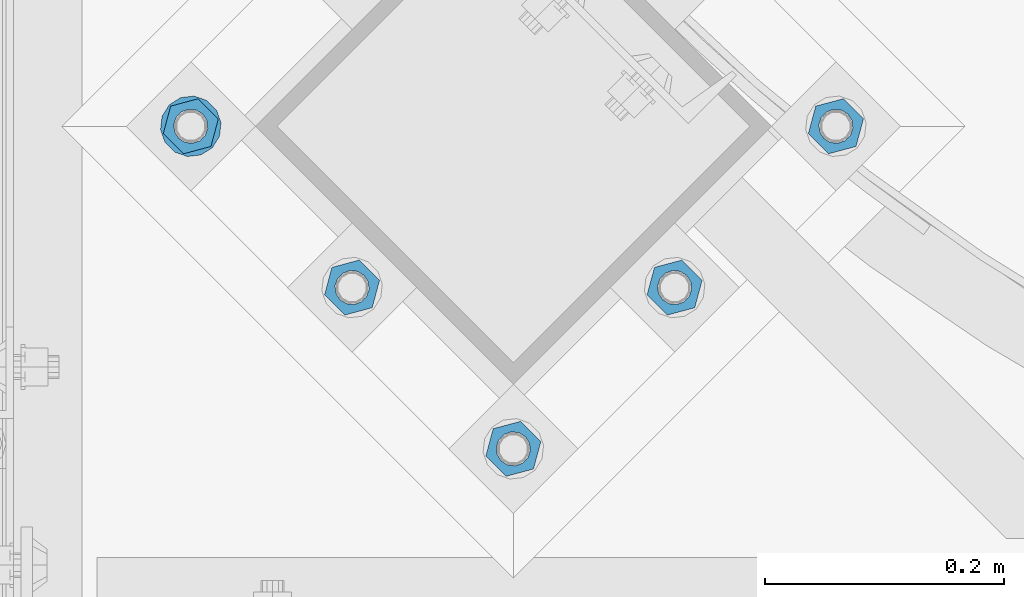
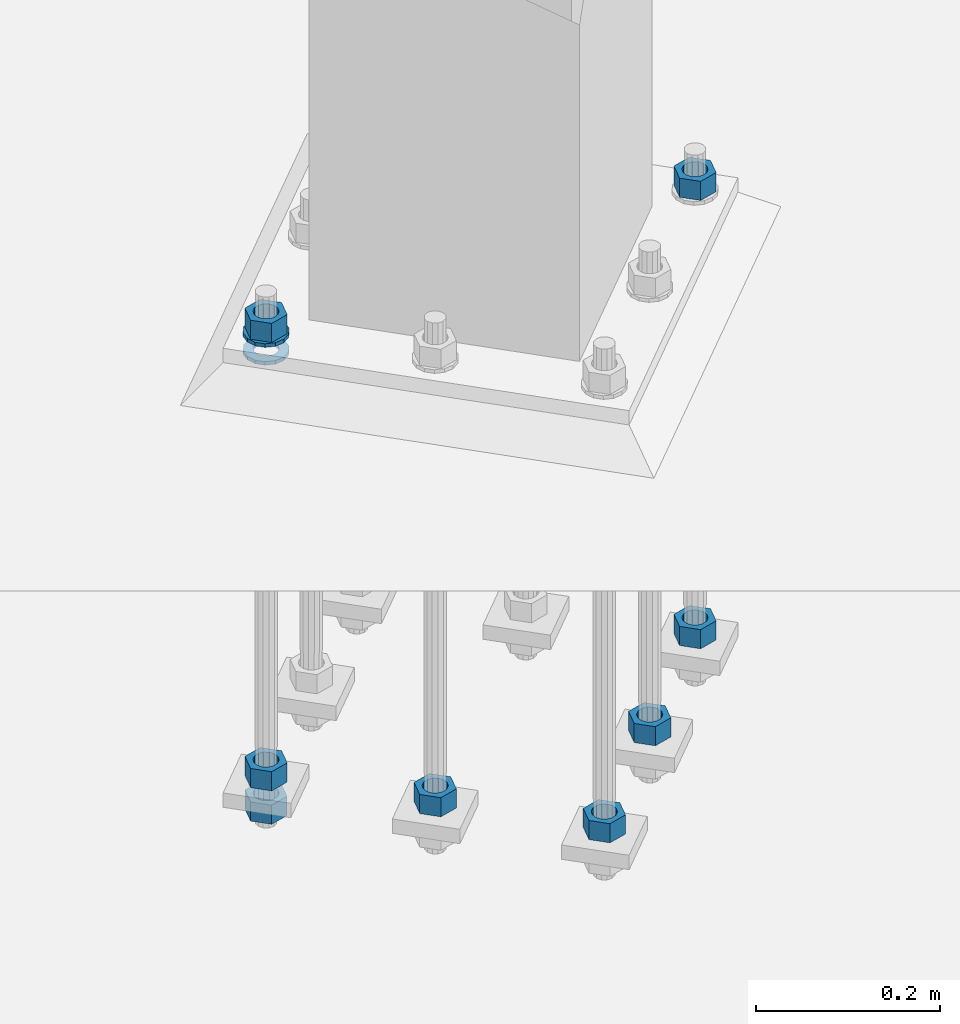
# One storey, part 861 of 1876: 10 columns, 1 element without a shape of its own.
"""IFC2X3 building model written with IfcOpenShell, lengths in millimetres."""

from ifc_helpers import new_model, si_unit, frame, origin_with_axes, place, context, subcontext, project, spatial, faceted_brep, material, type_object, element, aggregate, save


model = new_model("IFC2X3")

# Units and contexts
model_context = context("Model", 3, precision=1e-05, world=origin_with_axes())
body_context = subcontext(model_context, "Body", "Model", "MODEL_VIEW")
ifc_project = project(units=[si_unit("LENGTHUNIT", "METRE", prefix="MILLI"), si_unit("AREAUNIT", "SQUARE_METRE"), si_unit("VOLUMEUNIT", "CUBIC_METRE"), si_unit("MASSUNIT", "GRAM", prefix="KILO"), si_unit("TIMEUNIT", "SECOND"), si_unit("PLANEANGLEUNIT", "RADIAN"), si_unit("SOLIDANGLEUNIT", "STERADIAN"), si_unit("THERMODYNAMICTEMPERATUREUNIT", "DEGREE_CELSIUS"), si_unit("LUMINOUSINTENSITYUNIT", "LUMEN")], contexts=[model_context])

# Site, building, storey
site_placement = place(None, origin_with_axes())
site = spatial("IfcSite", under=ifc_project, at=site_placement, CompositionType="ELEMENT")
building_placement = place(site_placement, origin_with_axes())
building = spatial("IfcBuilding", under=site, at=building_placement, Name="Undefined", CompositionType="ELEMENT")
storey_placement = place(building_placement, origin_with_axes())
storey = spatial("IfcBuildingStorey", under=building, at=storey_placement, Name="Undefined", CompositionType="ELEMENT", Elevation=0.0)

# Assembly, columns
assembly_placement = place(storey_placement, origin_with_axes())
assembly = element("IfcElementAssembly", 1, at=assembly_placement, inside=storey, Name="TEMPLATE", AssemblyPlace="NOTDEFINED", PredefinedType="RIGID_FRAME")
ifc_material_1 = material(Name="STEEL/A563")
column_type_1 = type_object("IfcColumnType", Name="1_HEAVY_HEX_NUT", PredefinedType="NOTDEFINED")
column_1_placement = place(assembly_placement, frame((4052.32985770481, -14987.6778259281, -508.0), z_axis=(0.707106781186548, 0.707106781186547, 0.0), x_axis=(0.0, 0.0, -1.0)))
column_1 = element("IfcColumn", 2, at=column_1_placement, type_object=column_type_1, material=ifc_material_1, Name="NUT", ObjectType="1_HEAVY_HEX_NUT", context=body_context, shape_type="Brep", body=[
    faceted_brep([(0.0, -23.8099994659442, 9.09494701772928e-13), (0.0, -11.9099998474121, -20.6200008392352), (25.4, -11.9099998474157, -20.6200008392361), (25.4, -23.8099994659478, 0.0), (0.0, 11.9099998474157, -20.620000839237), (25.4, 11.9099998474121, -20.620000839237), (0.0, 23.8099994659478, 9.09494701772928e-13), (25.4, 23.8099994659442, 0.0), (0.0, 11.9099998474157, 20.620000839237), (25.4, 11.9099998474121, 20.620000839237), (0.0, -11.9099998474121, 20.6200008392389), (25.4, -11.9099998474157, 20.6200008392379), (0.0, 1.81898940354586e-12, 14.2899999618567), (0.0, 6.20019861543915, 12.8748450879584), (25.4, 6.20019861543733, 12.8748450879593), (25.4, 0.0, 14.2899999618558), (0.0, 11.1723718546473, 8.90966924477925), (25.4, 11.1723718546436, 8.90966924477925), (0.0, 13.9317198278914, 3.17982413774916), (25.4, 13.9317198278877, 3.17982413775007), (0.0, 13.9317198278914, -3.17982413774644), (25.4, 13.9317198278895, -3.17982413774735), (0.0, 11.1723718546473, -8.90966924477834), (25.4, 11.1723718546455, -8.90966924477925), (0.0, 6.20019861544279, -12.8748450879575), (25.4, 6.20019861543915, -12.8748450879584), (0.0, 3.63797880709171e-12, -14.2899999618548), (25.4, -3.63797880709171e-12, -14.2899999618548), (0.0, -6.20019861543733, -12.8748450879566), (25.4, -6.20019861544097, -12.8748450879584), (0.0, -11.1723718546455, -8.90966924477743), (25.4, -11.1723718546473, -8.90966924477834), (0.0, -13.9317198278877, -3.17982413774735), (25.4, -13.9317198278914, -3.17982413774826), (0.0, -13.9317198278895, 3.17982413774735), (25.4, -13.9317198278914, 3.17982413774826), (0.0, -11.1723718546455, 8.90966924477925), (25.4, -11.1723718546473, 8.90966924478016), (0.0, -6.20019861543915, 12.8748450879593), (25.4, -6.20019861544279, 12.8748450879593)], [[[0, 1, 2, 3]], [[1, 4, 5, 2]], [[4, 6, 7, 5]], [[6, 8, 9, 7]], [[8, 10, 11, 9]], [[10, 0, 3, 11]], [[12, 13, 14, 15]], [[13, 16, 17, 14]], [[16, 18, 19, 17]], [[18, 20, 21, 19]], [[20, 22, 23, 21]], [[22, 24, 25, 23]], [[24, 26, 27, 25]], [[26, 28, 29, 27]], [[28, 30, 31, 29]], [[30, 32, 33, 31]], [[32, 34, 35, 33]], [[34, 36, 37, 35]], [[36, 38, 39, 37]], [[38, 12, 15, 39]], [[5, 7, 9, 11, 3, 2], [17, 19, 21, 23, 25, 27, 29, 31, 33, 35, 37, 39, 15, 14]], [[10, 8, 6, 4, 1, 0], [38, 36, 34, 32, 30, 28, 26, 24, 22, 20, 18, 16, 13, 12]]]),
])
column_2_placement = place(assembly_placement, frame((3917.62601588861, -15122.3816677443, -508.0), z_axis=(0.707106781186548, 0.707106781186547, 0.0), x_axis=(0.0, 0.0, -1.0)))
column_2 = element("IfcColumn", 3, at=column_2_placement, type_object=column_type_1, material=ifc_material_1, Name="NUT", ObjectType="1_HEAVY_HEX_NUT", context=body_context, shape_type="Brep", body=[
    faceted_brep([(0.0, -23.8099994659442, 9.09494701772928e-13), (0.0, -11.9099998474121, -20.6200008392352), (25.4, -11.9099998474157, -20.6200008392361), (25.4, -23.8099994659478, 0.0), (0.0, 11.9099998474157, -20.620000839237), (25.4, 11.9099998474121, -20.620000839237), (0.0, 23.8099994659478, 9.09494701772928e-13), (25.4, 23.8099994659442, 0.0), (0.0, 11.9099998474157, 20.620000839237), (25.4, 11.9099998474121, 20.620000839237), (0.0, -11.9099998474121, 20.6200008392389), (25.4, -11.9099998474157, 20.6200008392379), (0.0, 1.81898940354586e-12, 14.2899999618567), (0.0, 6.20019861543915, 12.8748450879584), (25.4, 6.20019861543733, 12.8748450879593), (25.4, 0.0, 14.2899999618558), (0.0, 11.1723718546473, 8.90966924477925), (25.4, 11.1723718546436, 8.90966924477925), (0.0, 13.9317198278914, 3.17982413774916), (25.4, 13.9317198278877, 3.17982413775007), (0.0, 13.9317198278914, -3.17982413774644), (25.4, 13.9317198278895, -3.17982413774735), (0.0, 11.1723718546473, -8.90966924477834), (25.4, 11.1723718546455, -8.90966924477925), (0.0, 6.20019861544279, -12.8748450879575), (25.4, 6.20019861543915, -12.8748450879584), (0.0, 3.63797880709171e-12, -14.2899999618548), (25.4, -3.63797880709171e-12, -14.2899999618548), (0.0, -6.20019861543733, -12.8748450879566), (25.4, -6.20019861544097, -12.8748450879584), (0.0, -11.1723718546455, -8.90966924477743), (25.4, -11.1723718546473, -8.90966924477834), (0.0, -13.9317198278877, -3.17982413774735), (25.4, -13.9317198278914, -3.17982413774826), (0.0, -13.9317198278895, 3.17982413774735), (25.4, -13.9317198278914, 3.17982413774826), (0.0, -11.1723718546455, 8.90966924477925), (25.4, -11.1723718546473, 8.90966924478016), (0.0, -6.20019861543915, 12.8748450879593), (25.4, -6.20019861544279, 12.8748450879593)], [[[0, 1, 2, 3]], [[1, 4, 5, 2]], [[4, 6, 7, 5]], [[6, 8, 9, 7]], [[8, 10, 11, 9]], [[10, 0, 3, 11]], [[12, 13, 14, 15]], [[13, 16, 17, 14]], [[16, 18, 19, 17]], [[18, 20, 21, 19]], [[20, 22, 23, 21]], [[22, 24, 25, 23]], [[24, 26, 27, 25]], [[26, 28, 29, 27]], [[28, 30, 31, 29]], [[30, 32, 33, 31]], [[32, 34, 35, 33]], [[34, 36, 37, 35]], [[36, 38, 39, 37]], [[38, 12, 15, 39]], [[5, 7, 9, 11, 3, 2], [17, 19, 21, 23, 25, 27, 29, 31, 33, 35, 37, 39, 15, 14]], [[10, 8, 6, 4, 1, 0], [38, 36, 34, 32, 30, 28, 26, 24, 22, 20, 18, 16, 13, 12]]]),
])
column_3_placement = place(assembly_placement, frame((3782.92217407241, -15257.0855095605, -508.0), z_axis=(0.707106781186548, 0.707106781186547, 0.0), x_axis=(0.0, 0.0, -1.0)))
column_3 = element("IfcColumn", 4, at=column_3_placement, type_object=column_type_1, material=ifc_material_1, Name="NUT", ObjectType="1_HEAVY_HEX_NUT", context=body_context, shape_type="Brep", body=[
    faceted_brep([(0.0, -23.8099994659442, 9.09494701772928e-13), (0.0, -11.9099998474121, -20.6200008392352), (25.4, -11.9099998474157, -20.6200008392361), (25.4, -23.8099994659478, 0.0), (0.0, 11.9099998474157, -20.620000839237), (25.4, 11.9099998474121, -20.620000839237), (0.0, 23.8099994659478, 9.09494701772928e-13), (25.4, 23.8099994659442, 0.0), (0.0, 11.9099998474157, 20.620000839237), (25.4, 11.9099998474121, 20.620000839237), (0.0, -11.9099998474121, 20.6200008392389), (25.4, -11.9099998474157, 20.6200008392379), (0.0, 1.81898940354586e-12, 14.2899999618567), (0.0, 6.20019861543915, 12.8748450879584), (25.4, 6.20019861543733, 12.8748450879593), (25.4, 0.0, 14.2899999618558), (0.0, 11.1723718546473, 8.90966924477925), (25.4, 11.1723718546436, 8.90966924477925), (0.0, 13.9317198278914, 3.17982413774916), (25.4, 13.9317198278877, 3.17982413775007), (0.0, 13.9317198278914, -3.17982413774644), (25.4, 13.9317198278895, -3.17982413774735), (0.0, 11.1723718546473, -8.90966924477834), (25.4, 11.1723718546455, -8.90966924477925), (0.0, 6.20019861544279, -12.8748450879575), (25.4, 6.20019861543915, -12.8748450879584), (0.0, 3.63797880709171e-12, -14.2899999618548), (25.4, -3.63797880709171e-12, -14.2899999618548), (0.0, -6.20019861543733, -12.8748450879566), (25.4, -6.20019861544097, -12.8748450879584), (0.0, -11.1723718546455, -8.90966924477743), (25.4, -11.1723718546473, -8.90966924477834), (0.0, -13.9317198278877, -3.17982413774735), (25.4, -13.9317198278914, -3.17982413774826), (0.0, -13.9317198278895, 3.17982413774735), (25.4, -13.9317198278914, 3.17982413774826), (0.0, -11.1723718546455, 8.90966924477925), (25.4, -11.1723718546473, 8.90966924478016), (0.0, -6.20019861543915, 12.8748450879593), (25.4, -6.20019861544279, 12.8748450879593)], [[[0, 1, 2, 3]], [[1, 4, 5, 2]], [[4, 6, 7, 5]], [[6, 8, 9, 7]], [[8, 10, 11, 9]], [[10, 0, 3, 11]], [[12, 13, 14, 15]], [[13, 16, 17, 14]], [[16, 18, 19, 17]], [[18, 20, 21, 19]], [[20, 22, 23, 21]], [[22, 24, 25, 23]], [[24, 26, 27, 25]], [[26, 28, 29, 27]], [[28, 30, 31, 29]], [[30, 32, 33, 31]], [[32, 34, 35, 33]], [[34, 36, 37, 35]], [[36, 38, 39, 37]], [[38, 12, 15, 39]], [[5, 7, 9, 11, 3, 2], [17, 19, 21, 23, 25, 27, 29, 31, 33, 35, 37, 39, 15, 14]], [[10, 8, 6, 4, 1, 0], [38, 36, 34, 32, 30, 28, 26, 24, 22, 20, 18, 16, 13, 12]]]),
])
column_4_placement = place(assembly_placement, frame((3648.21833225621, -15122.3816677443, -508.0), z_axis=(0.707106781186548, 0.707106781186547, 0.0), x_axis=(0.0, 0.0, -1.0)))
column_4 = element("IfcColumn", 5, at=column_4_placement, type_object=column_type_1, material=ifc_material_1, Name="NUT", ObjectType="1_HEAVY_HEX_NUT", context=body_context, shape_type="Brep", body=[
    faceted_brep([(0.0, -23.8099994659442, 9.09494701772928e-13), (0.0, -11.9099998474121, -20.6200008392352), (25.4, -11.9099998474157, -20.6200008392361), (25.4, -23.8099994659478, 0.0), (0.0, 11.9099998474157, -20.620000839237), (25.4, 11.9099998474121, -20.620000839237), (0.0, 23.8099994659478, 9.09494701772928e-13), (25.4, 23.8099994659442, 0.0), (0.0, 11.9099998474157, 20.620000839237), (25.4, 11.9099998474121, 20.620000839237), (0.0, -11.9099998474121, 20.6200008392389), (25.4, -11.9099998474157, 20.6200008392379), (0.0, 1.81898940354586e-12, 14.2899999618567), (0.0, 6.20019861543915, 12.8748450879584), (25.4, 6.20019861543733, 12.8748450879593), (25.4, 0.0, 14.2899999618558), (0.0, 11.1723718546473, 8.90966924477925), (25.4, 11.1723718546436, 8.90966924477925), (0.0, 13.9317198278914, 3.17982413774916), (25.4, 13.9317198278877, 3.17982413775007), (0.0, 13.9317198278914, -3.17982413774644), (25.4, 13.9317198278895, -3.17982413774735), (0.0, 11.1723718546473, -8.90966924477834), (25.4, 11.1723718546455, -8.90966924477925), (0.0, 6.20019861544279, -12.8748450879575), (25.4, 6.20019861543915, -12.8748450879584), (0.0, 3.63797880709171e-12, -14.2899999618548), (25.4, -3.63797880709171e-12, -14.2899999618548), (0.0, -6.20019861543733, -12.8748450879566), (25.4, -6.20019861544097, -12.8748450879584), (0.0, -11.1723718546455, -8.90966924477743), (25.4, -11.1723718546473, -8.90966924477834), (0.0, -13.9317198278877, -3.17982413774735), (25.4, -13.9317198278914, -3.17982413774826), (0.0, -13.9317198278895, 3.17982413774735), (25.4, -13.9317198278914, 3.17982413774826), (0.0, -11.1723718546455, 8.90966924477925), (25.4, -11.1723718546473, 8.90966924478016), (0.0, -6.20019861543915, 12.8748450879593), (25.4, -6.20019861544279, 12.8748450879593)], [[[0, 1, 2, 3]], [[1, 4, 5, 2]], [[4, 6, 7, 5]], [[6, 8, 9, 7]], [[8, 10, 11, 9]], [[10, 0, 3, 11]], [[12, 13, 14, 15]], [[13, 16, 17, 14]], [[16, 18, 19, 17]], [[18, 20, 21, 19]], [[20, 22, 23, 21]], [[22, 24, 25, 23]], [[24, 26, 27, 25]], [[26, 28, 29, 27]], [[28, 30, 31, 29]], [[30, 32, 33, 31]], [[32, 34, 35, 33]], [[34, 36, 37, 35]], [[36, 38, 39, 37]], [[38, 12, 15, 39]], [[5, 7, 9, 11, 3, 2], [17, 19, 21, 23, 25, 27, 29, 31, 33, 35, 37, 39, 15, 14]], [[10, 8, 6, 4, 1, 0], [38, 36, 34, 32, 30, 28, 26, 24, 22, 20, 18, 16, 13, 12]]]),
])
column_5_placement = place(assembly_placement, frame((3513.51449044002, -14987.6778259281, -508.0), z_axis=(-0.707106781186547, -0.707106781186548, 0.0), x_axis=(0.0, 0.0, -1.0)))
column_5 = element("IfcColumn", 6, at=column_5_placement, type_object=column_type_1, material=ifc_material_1, Name="NUT", ObjectType="1_HEAVY_HEX_NUT", context=body_context, shape_type="Brep", body=[
    faceted_brep([(0.0, -23.8099994659442, 9.09494701772928e-13), (0.0, -11.9099998474121, -20.6200008392352), (25.4, -11.9099998474157, -20.6200008392361), (25.4, -23.8099994659478, 0.0), (0.0, 11.9099998474157, -20.620000839237), (25.4, 11.9099998474121, -20.620000839237), (0.0, 23.8099994659478, 9.09494701772928e-13), (25.4, 23.8099994659442, 0.0), (0.0, 11.9099998474157, 20.620000839237), (25.4, 11.9099998474121, 20.620000839237), (0.0, -11.9099998474121, 20.6200008392389), (25.4, -11.9099998474157, 20.6200008392379), (0.0, 1.81898940354586e-12, 14.2899999618567), (0.0, 6.20019861543915, 12.8748450879584), (25.4, 6.20019861543733, 12.8748450879593), (25.4, 0.0, 14.2899999618558), (0.0, 11.1723718546473, 8.90966924477925), (25.4, 11.1723718546436, 8.90966924477925), (0.0, 13.9317198278914, 3.17982413774916), (25.4, 13.9317198278877, 3.17982413775007), (0.0, 13.9317198278914, -3.17982413774644), (25.4, 13.9317198278895, -3.17982413774735), (0.0, 11.1723718546473, -8.90966924477834), (25.4, 11.1723718546455, -8.90966924477925), (0.0, 6.20019861544279, -12.8748450879575), (25.4, 6.20019861543915, -12.8748450879584), (0.0, 3.63797880709171e-12, -14.2899999618548), (25.4, -3.63797880709171e-12, -14.2899999618548), (0.0, -6.20019861543733, -12.8748450879566), (25.4, -6.20019861544097, -12.8748450879584), (0.0, -11.1723718546455, -8.90966924477743), (25.4, -11.1723718546473, -8.90966924477834), (0.0, -13.9317198278877, -3.17982413774735), (25.4, -13.9317198278914, -3.17982413774826), (0.0, -13.9317198278895, 3.17982413774735), (25.4, -13.9317198278914, 3.17982413774826), (0.0, -11.1723718546455, 8.90966924477925), (25.4, -11.1723718546473, 8.90966924478016), (0.0, -6.20019861543915, 12.8748450879593), (25.4, -6.20019861544279, 12.8748450879593)], [[[0, 1, 2, 3]], [[1, 4, 5, 2]], [[4, 6, 7, 5]], [[6, 8, 9, 7]], [[8, 10, 11, 9]], [[10, 0, 3, 11]], [[12, 13, 14, 15]], [[13, 16, 17, 14]], [[16, 18, 19, 17]], [[18, 20, 21, 19]], [[20, 22, 23, 21]], [[22, 24, 25, 23]], [[24, 26, 27, 25]], [[26, 28, 29, 27]], [[28, 30, 31, 29]], [[30, 32, 33, 31]], [[32, 34, 35, 33]], [[34, 36, 37, 35]], [[36, 38, 39, 37]], [[38, 12, 15, 39]], [[5, 7, 9, 11, 3, 2], [17, 19, 21, 23, 25, 27, 29, 31, 33, 35, 37, 39, 15, 14]], [[10, 8, 6, 4, 1, 0], [38, 36, 34, 32, 30, 28, 26, 24, 22, 20, 18, 16, 13, 12]]]),
])
column_6_placement = place(assembly_placement, frame((4052.32985770481, -14987.6778259281, 87.3125), z_axis=(0.707106781186548, 0.707106781186547, 0.0), x_axis=(0.0, 0.0, -1.0)))
column_6 = element("IfcColumn", 7, at=column_6_placement, type_object=column_type_1, material=ifc_material_1, Name="NUT", ObjectType="1_HEAVY_HEX_NUT", context=body_context, shape_type="Brep", body=[
    faceted_brep([(0.0, -23.8099994659442, 9.09494701772928e-13), (0.0, -11.9099998474121, -20.6200008392352), (25.4, -11.9099998474157, -20.6200008392361), (25.4, -23.8099994659478, 0.0), (0.0, 11.9099998474157, -20.620000839237), (25.4, 11.9099998474121, -20.620000839237), (0.0, 23.8099994659478, 9.09494701772928e-13), (25.4, 23.8099994659442, 0.0), (0.0, 11.9099998474157, 20.620000839237), (25.4, 11.9099998474121, 20.620000839237), (0.0, -11.9099998474121, 20.6200008392389), (25.4, -11.9099998474157, 20.6200008392379), (0.0, 1.81898940354586e-12, 14.2899999618567), (0.0, 6.20019861543915, 12.8748450879584), (25.4, 6.20019861543733, 12.8748450879593), (25.4, 0.0, 14.2899999618558), (0.0, 11.1723718546473, 8.90966924477925), (25.4, 11.1723718546436, 8.90966924477925), (0.0, 13.9317198278914, 3.17982413774916), (25.4, 13.9317198278877, 3.17982413775007), (0.0, 13.9317198278914, -3.17982413774644), (25.4, 13.9317198278895, -3.17982413774735), (0.0, 11.1723718546473, -8.90966924477834), (25.4, 11.1723718546455, -8.90966924477925), (0.0, 6.20019861544279, -12.8748450879575), (25.4, 6.20019861543915, -12.8748450879584), (0.0, 3.63797880709171e-12, -14.2899999618548), (25.4, -3.63797880709171e-12, -14.2899999618548), (0.0, -6.20019861543733, -12.8748450879566), (25.4, -6.20019861544097, -12.8748450879584), (0.0, -11.1723718546455, -8.90966924477743), (25.4, -11.1723718546473, -8.90966924477834), (0.0, -13.9317198278877, -3.17982413774735), (25.4, -13.9317198278914, -3.17982413774826), (0.0, -13.9317198278895, 3.17982413774735), (25.4, -13.9317198278914, 3.17982413774826), (0.0, -11.1723718546455, 8.90966924477925), (25.4, -11.1723718546473, 8.90966924478016), (0.0, -6.20019861543915, 12.8748450879593), (25.4, -6.20019861544279, 12.8748450879593)], [[[0, 1, 2, 3]], [[1, 4, 5, 2]], [[4, 6, 7, 5]], [[6, 8, 9, 7]], [[8, 10, 11, 9]], [[10, 0, 3, 11]], [[12, 13, 14, 15]], [[13, 16, 17, 14]], [[16, 18, 19, 17]], [[18, 20, 21, 19]], [[20, 22, 23, 21]], [[22, 24, 25, 23]], [[24, 26, 27, 25]], [[26, 28, 29, 27]], [[28, 30, 31, 29]], [[30, 32, 33, 31]], [[32, 34, 35, 33]], [[34, 36, 37, 35]], [[36, 38, 39, 37]], [[38, 12, 15, 39]], [[5, 7, 9, 11, 3, 2], [17, 19, 21, 23, 25, 27, 29, 31, 33, 35, 37, 39, 15, 14]], [[10, 8, 6, 4, 1, 0], [38, 36, 34, 32, 30, 28, 26, 24, 22, 20, 18, 16, 13, 12]]]),
])
column_7_placement = place(assembly_placement, frame((3513.51449044002, -14987.6778259281, 87.3125), z_axis=(-0.707106781186547, -0.707106781186548, 0.0), x_axis=(0.0, 0.0, -1.0)))
column_7 = element("IfcColumn", 8, at=column_7_placement, type_object=column_type_1, material=ifc_material_1, Name="NUT", ObjectType="1_HEAVY_HEX_NUT", context=body_context, shape_type="Brep", body=[
    faceted_brep([(0.0, -23.8099994659442, 9.09494701772928e-13), (0.0, -11.9099998474121, -20.6200008392352), (25.4, -11.9099998474157, -20.6200008392361), (25.4, -23.8099994659478, 0.0), (0.0, 11.9099998474157, -20.620000839237), (25.4, 11.9099998474121, -20.620000839237), (0.0, 23.8099994659478, 9.09494701772928e-13), (25.4, 23.8099994659442, 0.0), (0.0, 11.9099998474157, 20.620000839237), (25.4, 11.9099998474121, 20.620000839237), (0.0, -11.9099998474121, 20.6200008392389), (25.4, -11.9099998474157, 20.6200008392379), (0.0, 1.81898940354586e-12, 14.2899999618567), (0.0, 6.20019861543915, 12.8748450879584), (25.4, 6.20019861543733, 12.8748450879593), (25.4, 0.0, 14.2899999618558), (0.0, 11.1723718546473, 8.90966924477925), (25.4, 11.1723718546436, 8.90966924477925), (0.0, 13.9317198278914, 3.17982413774916), (25.4, 13.9317198278877, 3.17982413775007), (0.0, 13.9317198278914, -3.17982413774644), (25.4, 13.9317198278895, -3.17982413774735), (0.0, 11.1723718546473, -8.90966924477834), (25.4, 11.1723718546455, -8.90966924477925), (0.0, 6.20019861544279, -12.8748450879575), (25.4, 6.20019861543915, -12.8748450879584), (0.0, 3.63797880709171e-12, -14.2899999618548), (25.4, -3.63797880709171e-12, -14.2899999618548), (0.0, -6.20019861543733, -12.8748450879566), (25.4, -6.20019861544097, -12.8748450879584), (0.0, -11.1723718546455, -8.90966924477743), (25.4, -11.1723718546473, -8.90966924477834), (0.0, -13.9317198278877, -3.17982413774735), (25.4, -13.9317198278914, -3.17982413774826), (0.0, -13.9317198278895, 3.17982413774735), (25.4, -13.9317198278914, 3.17982413774826), (0.0, -11.1723718546455, 8.90966924477925), (25.4, -11.1723718546473, 8.90966924478016), (0.0, -6.20019861543915, 12.8748450879593), (25.4, -6.20019861544279, 12.8748450879593)], [[[0, 1, 2, 3]], [[1, 4, 5, 2]], [[4, 6, 7, 5]], [[6, 8, 9, 7]], [[8, 10, 11, 9]], [[10, 0, 3, 11]], [[12, 13, 14, 15]], [[13, 16, 17, 14]], [[16, 18, 19, 17]], [[18, 20, 21, 19]], [[20, 22, 23, 21]], [[22, 24, 25, 23]], [[24, 26, 27, 25]], [[26, 28, 29, 27]], [[28, 30, 31, 29]], [[30, 32, 33, 31]], [[32, 34, 35, 33]], [[34, 36, 37, 35]], [[36, 38, 39, 37]], [[38, 12, 15, 39]], [[5, 7, 9, 11, 3, 2], [17, 19, 21, 23, 25, 27, 29, 31, 33, 35, 37, 39, 15, 14]], [[10, 8, 6, 4, 1, 0], [38, 36, 34, 32, 30, 28, 26, 24, 22, 20, 18, 16, 13, 12]]]),
])
column_8_placement = place(assembly_placement, frame((3513.51449044006, -14987.6778259282, -552.45), z_axis=(-0.707106781186547, -0.707106781186548, 0.0), x_axis=(0.0, 0.0, -1.0)))
column_8 = element("IfcColumn", 9, at=column_8_placement, type_object=column_type_1, material=ifc_material_1, Name="NUT", ObjectType="1_HEAVY_HEX_NUT", context=body_context, shape_type="Brep", body=[
    faceted_brep([(0.0, -23.8099994659442, 9.09494701772928e-13), (0.0, -11.9099998474121, -20.6200008392352), (25.4, -11.9099998474157, -20.6200008392361), (25.4, -23.8099994659478, 0.0), (0.0, 11.9099998474157, -20.620000839237), (25.4, 11.9099998474121, -20.620000839237), (0.0, 23.8099994659478, 9.09494701772928e-13), (25.4, 23.8099994659442, 0.0), (0.0, 11.9099998474157, 20.620000839237), (25.4, 11.9099998474121, 20.620000839237), (0.0, -11.9099998474121, 20.6200008392389), (25.4, -11.9099998474157, 20.6200008392379), (0.0, 1.81898940354586e-12, 14.2899999618567), (0.0, 6.20019861543915, 12.8748450879584), (25.4, 6.20019861543733, 12.8748450879593), (25.4, 0.0, 14.2899999618558), (0.0, 11.1723718546473, 8.90966924477925), (25.4, 11.1723718546436, 8.90966924477925), (0.0, 13.9317198278914, 3.17982413774916), (25.4, 13.9317198278877, 3.17982413775007), (0.0, 13.9317198278914, -3.17982413774644), (25.4, 13.9317198278895, -3.17982413774735), (0.0, 11.1723718546473, -8.90966924477834), (25.4, 11.1723718546455, -8.90966924477925), (0.0, 6.20019861544279, -12.8748450879575), (25.4, 6.20019861543915, -12.8748450879584), (0.0, 3.63797880709171e-12, -14.2899999618548), (25.4, -3.63797880709171e-12, -14.2899999618548), (0.0, -6.20019861543733, -12.8748450879566), (25.4, -6.20019861544097, -12.8748450879584), (0.0, -11.1723718546455, -8.90966924477743), (25.4, -11.1723718546473, -8.90966924477834), (0.0, -13.9317198278877, -3.17982413774735), (25.4, -13.9317198278914, -3.17982413774826), (0.0, -13.9317198278895, 3.17982413774735), (25.4, -13.9317198278914, 3.17982413774826), (0.0, -11.1723718546455, 8.90966924477925), (25.4, -11.1723718546473, 8.90966924478016), (0.0, -6.20019861543915, 12.8748450879593), (25.4, -6.20019861544279, 12.8748450879593)], [[[0, 1, 2, 3]], [[1, 4, 5, 2]], [[4, 6, 7, 5]], [[6, 8, 9, 7]], [[8, 10, 11, 9]], [[10, 0, 3, 11]], [[12, 13, 14, 15]], [[13, 16, 17, 14]], [[16, 18, 19, 17]], [[18, 20, 21, 19]], [[20, 22, 23, 21]], [[22, 24, 25, 23]], [[24, 26, 27, 25]], [[26, 28, 29, 27]], [[28, 30, 31, 29]], [[30, 32, 33, 31]], [[32, 34, 35, 33]], [[34, 36, 37, 35]], [[36, 38, 39, 37]], [[38, 12, 15, 39]], [[5, 7, 9, 11, 3, 2], [17, 19, 21, 23, 25, 27, 29, 31, 33, 35, 37, 39, 15, 14]], [[10, 8, 6, 4, 1, 0], [38, 36, 34, 32, 30, 28, 26, 24, 22, 20, 18, 16, 13, 12]]]),
])
ifc_material_2 = material(Name="STEEL/F436")
column_type_2 = type_object("IfcColumnType", Name="1_WASHER", PredefinedType="NOTDEFINED")
column_9_placement = place(assembly_placement, frame((3513.51449043993, -14987.6778259278, 38.1), z_axis=(-0.707106781186547, -0.707106781186548, 0.0), x_axis=(0.0, 0.0, -1.0)))
column_9 = element("IfcColumn", 10, at=column_9_placement, type_object=column_type_2, material=ifc_material_2, Name="WASHER", ObjectType="1_WASHER", context=body_context, shape_type="Brep", body=[
    faceted_brep([(0.0, -25.3999996185375, 0.0), (0.0, -22.8846089010331, -11.0206468080742), (4.7625, -22.8846089010331, -11.0206468080742), (4.7625, -25.3999996185375, 0.0), (0.0, -15.8366407293743, -19.8585193564477), (4.7625, -15.8366407293743, -19.8585193564477), (0.0, -5.65203163760816, -24.7631685975166), (4.7625, -5.65203163760816, -24.7631685975166), (0.0, 5.65203163760452, -24.7631685975166), (4.7625, 5.65203163760452, -24.7631685975166), (0.0, 15.8366407293706, -19.858519356445), (4.7625, 15.8366407293706, -19.858519356445), (0.0, 22.8846089010331, -11.0206468080733), (4.7625, 22.8846089010331, -11.0206468080733), (0.0, 25.3999996185339, 9.09494701772928e-13), (4.7625, 25.3999996185339, 9.09494701772928e-13), (0.0, 22.8846089010331, 11.0206468080751), (4.7625, 22.8846089010331, 11.0206468080751), (0.0, 15.8366407293706, 19.8585193564486), (4.7625, 15.8366407293706, 19.8585193564486), (0.0, 5.65203163760452, 24.7631685975175), (4.7625, 5.65203163760452, 24.7631685975175), (0.0, -5.65203163760816, 24.7631685975175), (4.7625, -5.65203163760816, 24.7631685975175), (0.0, -15.8366407293724, 19.8585193564459), (4.7625, -15.8366407293724, 19.8585193564459), (0.0, -22.8846089010367, 11.0206468080751), (4.7625, -22.8846089010367, 11.0206468080751), (0.0, 1.81898940354586e-12, 14.2899999618567), (0.0, 6.20019861543915, 12.8748450879584), (4.7625, 6.20019861543733, 12.8748450879593), (4.7625, 0.0, 14.2899999618558), (0.0, 11.1723718546473, 8.90966924477925), (4.7625, 11.1723718546436, 8.90966924477925), (0.0, 13.9317198278914, 3.17982413774916), (4.7625, 13.9317198278877, 3.17982413775007), (0.0, 13.9317198278914, -3.17982413774644), (4.7625, 13.9317198278895, -3.17982413774735), (0.0, 11.1723718546473, -8.90966924477834), (4.7625, 11.1723718546455, -8.90966924477925), (0.0, 6.20019861544279, -12.8748450879575), (4.7625, 6.20019861543915, -12.8748450879584), (0.0, 3.63797880709171e-12, -14.2899999618548), (4.7625, -3.63797880709171e-12, -14.2899999618548), (0.0, -6.20019861543733, -12.8748450879566), (4.7625, -6.20019861544097, -12.8748450879584), (0.0, -11.1723718546455, -8.90966924477743), (4.7625, -11.1723718546473, -8.90966924477834), (0.0, -13.9317198278877, -3.17982413774735), (4.7625, -13.9317198278914, -3.17982413774826), (0.0, -13.9317198278895, 3.17982413774735), (4.7625, -13.9317198278914, 3.17982413774826), (0.0, -11.1723718546455, 8.90966924477925), (4.7625, -11.1723718546473, 8.90966924478016), (0.0, -6.20019861543915, 12.8748450879593), (4.7625, -6.20019861544279, 12.8748450879593)], [[[0, 1, 2, 3]], [[1, 4, 5, 2]], [[4, 6, 7, 5]], [[6, 8, 9, 7]], [[8, 10, 11, 9]], [[10, 12, 13, 11]], [[12, 14, 15, 13]], [[14, 16, 17, 15]], [[16, 18, 19, 17]], [[18, 20, 21, 19]], [[20, 22, 23, 21]], [[22, 24, 25, 23]], [[24, 26, 27, 25]], [[26, 0, 3, 27]], [[28, 29, 30, 31]], [[29, 32, 33, 30]], [[32, 34, 35, 33]], [[34, 36, 37, 35]], [[36, 38, 39, 37]], [[38, 40, 41, 39]], [[40, 42, 43, 41]], [[42, 44, 45, 43]], [[44, 46, 47, 45]], [[46, 48, 49, 47]], [[48, 50, 51, 49]], [[50, 52, 53, 51]], [[52, 54, 55, 53]], [[54, 28, 31, 55]], [[5, 7, 9, 11, 13, 15, 17, 19, 21, 23, 25, 27, 3, 2], [33, 35, 37, 39, 41, 43, 45, 47, 49, 51, 53, 55, 31, 30]], [[26, 24, 22, 20, 18, 16, 14, 12, 10, 8, 6, 4, 1, 0], [54, 52, 50, 48, 46, 44, 42, 40, 38, 36, 34, 32, 29, 28]]]),
])
column_10_placement = place(assembly_placement, frame((3513.51449043997, -14987.677825928, 61.9125), z_axis=(-0.707106781186547, -0.707106781186548, 0.0), x_axis=(0.0, 0.0, -1.0)))
column_10 = element("IfcColumn", 11, at=column_10_placement, type_object=column_type_2, material=ifc_material_2, Name="WASHER", ObjectType="1_WASHER", context=body_context, shape_type="Brep", body=[
    faceted_brep([(0.0, -25.3999996185375, 0.0), (0.0, -22.8846089010331, -11.0206468080742), (4.7625, -22.8846089010331, -11.0206468080742), (4.7625, -25.3999996185375, 0.0), (0.0, -15.8366407293743, -19.8585193564477), (4.7625, -15.8366407293743, -19.8585193564477), (0.0, -5.65203163760816, -24.7631685975166), (4.7625, -5.65203163760816, -24.7631685975166), (0.0, 5.65203163760452, -24.7631685975166), (4.7625, 5.65203163760452, -24.7631685975166), (0.0, 15.8366407293706, -19.858519356445), (4.7625, 15.8366407293706, -19.858519356445), (0.0, 22.8846089010331, -11.0206468080733), (4.7625, 22.8846089010331, -11.0206468080733), (0.0, 25.3999996185339, 9.09494701772928e-13), (4.7625, 25.3999996185339, 9.09494701772928e-13), (0.0, 22.8846089010331, 11.0206468080751), (4.7625, 22.8846089010331, 11.0206468080751), (0.0, 15.8366407293706, 19.8585193564486), (4.7625, 15.8366407293706, 19.8585193564486), (0.0, 5.65203163760452, 24.7631685975175), (4.7625, 5.65203163760452, 24.7631685975175), (0.0, -5.65203163760816, 24.7631685975175), (4.7625, -5.65203163760816, 24.7631685975175), (0.0, -15.8366407293724, 19.8585193564459), (4.7625, -15.8366407293724, 19.8585193564459), (0.0, -22.8846089010367, 11.0206468080751), (4.7625, -22.8846089010367, 11.0206468080751), (0.0, 1.81898940354586e-12, 14.2899999618567), (0.0, 6.20019861543915, 12.8748450879584), (4.7625, 6.20019861543733, 12.8748450879593), (4.7625, 0.0, 14.2899999618558), (0.0, 11.1723718546473, 8.90966924477925), (4.7625, 11.1723718546436, 8.90966924477925), (0.0, 13.9317198278914, 3.17982413774916), (4.7625, 13.9317198278877, 3.17982413775007), (0.0, 13.9317198278914, -3.17982413774644), (4.7625, 13.9317198278895, -3.17982413774735), (0.0, 11.1723718546473, -8.90966924477834), (4.7625, 11.1723718546455, -8.90966924477925), (0.0, 6.20019861544279, -12.8748450879575), (4.7625, 6.20019861543915, -12.8748450879584), (0.0, 3.63797880709171e-12, -14.2899999618548), (4.7625, -3.63797880709171e-12, -14.2899999618548), (0.0, -6.20019861543733, -12.8748450879566), (4.7625, -6.20019861544097, -12.8748450879584), (0.0, -11.1723718546455, -8.90966924477743), (4.7625, -11.1723718546473, -8.90966924477834), (0.0, -13.9317198278877, -3.17982413774735), (4.7625, -13.9317198278914, -3.17982413774826), (0.0, -13.9317198278895, 3.17982413774735), (4.7625, -13.9317198278914, 3.17982413774826), (0.0, -11.1723718546455, 8.90966924477925), (4.7625, -11.1723718546473, 8.90966924478016), (0.0, -6.20019861543915, 12.8748450879593), (4.7625, -6.20019861544279, 12.8748450879593)], [[[0, 1, 2, 3]], [[1, 4, 5, 2]], [[4, 6, 7, 5]], [[6, 8, 9, 7]], [[8, 10, 11, 9]], [[10, 12, 13, 11]], [[12, 14, 15, 13]], [[14, 16, 17, 15]], [[16, 18, 19, 17]], [[18, 20, 21, 19]], [[20, 22, 23, 21]], [[22, 24, 25, 23]], [[24, 26, 27, 25]], [[26, 0, 3, 27]], [[28, 29, 30, 31]], [[29, 32, 33, 30]], [[32, 34, 35, 33]], [[34, 36, 37, 35]], [[36, 38, 39, 37]], [[38, 40, 41, 39]], [[40, 42, 43, 41]], [[42, 44, 45, 43]], [[44, 46, 47, 45]], [[46, 48, 49, 47]], [[48, 50, 51, 49]], [[50, 52, 53, 51]], [[52, 54, 55, 53]], [[54, 28, 31, 55]], [[5, 7, 9, 11, 13, 15, 17, 19, 21, 23, 25, 27, 3, 2], [33, 35, 37, 39, 41, 43, 45, 47, 49, 51, 53, 55, 31, 30]], [[26, 24, 22, 20, 18, 16, 14, 12, 10, 8, 6, 4, 1, 0], [54, 52, 50, 48, 46, 44, 42, 40, 38, 36, 34, 32, 29, 28]]]),
])
aggregate(assembly, [column_1, column_2, column_3, column_4, column_5, column_6, column_7, column_9, column_10, column_8])

save(model, "model.ifc")
